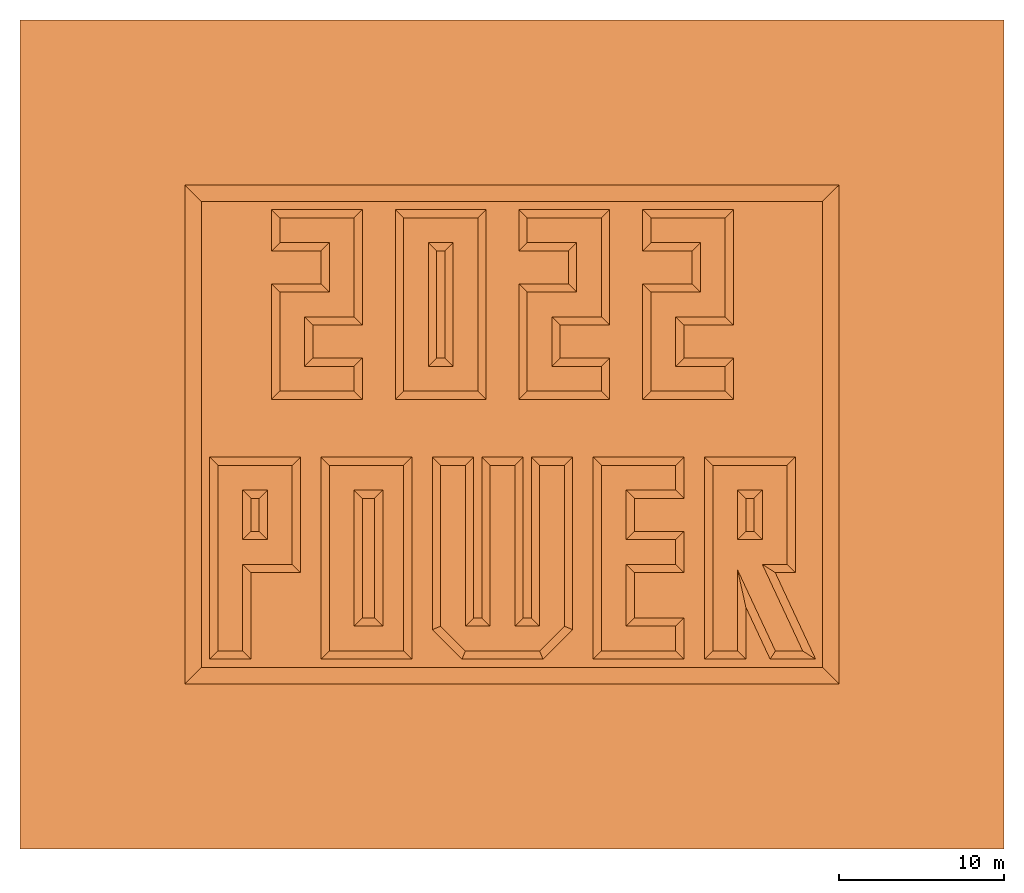
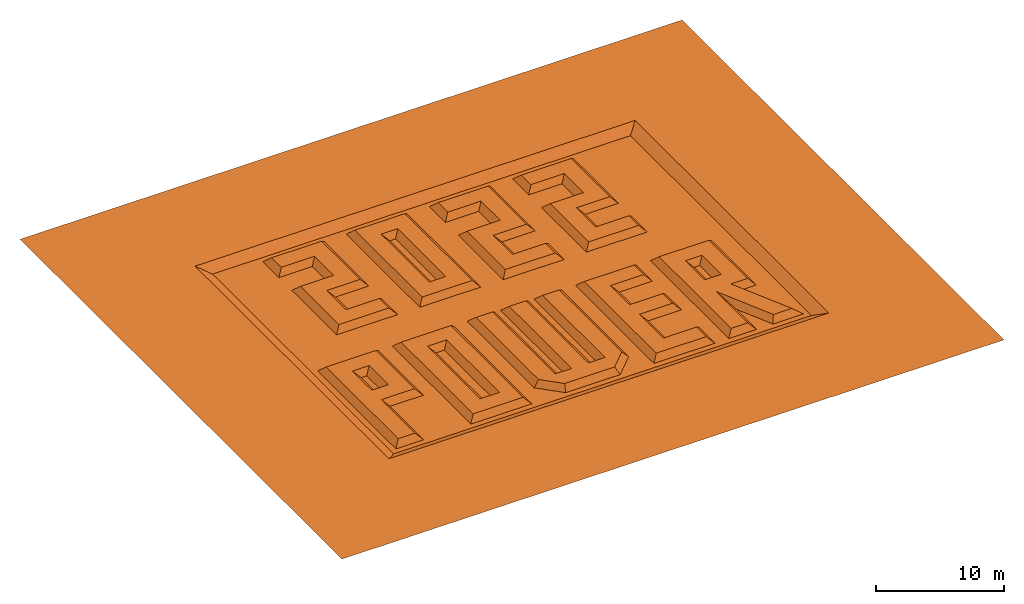
# One storey: 1 proxy.
"""IFC2X3 building model written with IfcOpenShell, lengths in millimetres."""

import ifcopenshell
import ifcopenshell.guid

model = None  # the IFC model being written
_history = None  # IfcOwnerHistory: only IFC2X3 demands one
_inside = {}  # id of a spatial element -> (the spatial element, [elements in it])
_under = {}  # id of a project, library or spatial element -> (it, [spatial elements below it])
_declared = {}  # id of a project -> (the project, [libraries it declares])
_typed = {}  # id of a type object -> (the type object, [elements of that type])
_made_of = {}  # id of a material, layer set ... -> (it, [elements and type objects made of it])


def new_model(schema):
    """Start an empty IFC model of exactly this schema.

    Asked for "IFC4X3", IfcOpenShell would pick the latest addendum, in which some entities
    have other attributes; the version numbers below select the first issue.
    IFC2X3 requires an IfcOwnerHistory on every rooted entity: one is made here for all.
    """
    global model, _history
    if schema == "IFC4X3":
        model = ifcopenshell.file(schema_version=(4, 3, 0, 0))
    else:
        model = ifcopenshell.file(schema=schema)
    _inside.clear()
    _under.clear()
    _declared.clear()
    _typed.clear()
    _made_of.clear()
    _history = None
    if model.schema == "IFC2X3":
        org = make("IfcOrganization", Name="unknown")
        user = make(
            "IfcPersonAndOrganization",
            ThePerson=make("IfcPerson", FamilyName="unknown"),
            TheOrganization=org,
        )
        app = make(
            "IfcApplication",
            ApplicationDeveloper=org,
            Version="unknown",
            ApplicationFullName="unknown",
            ApplicationIdentifier="unknown",
        )
        _history = make(
            "IfcOwnerHistory",
            OwningUser=user,
            OwningApplication=app,
            ChangeAction="ADDED",
            CreationDate=0,
        )
    return model


def make(cls, **values):
    """One entity of the class cls with the attributes given. An attribute that is None is left unset."""
    return model.create_entity(
        cls, **{name: value for name, value in values.items() if value is not None}
    )


def entity(cls, *values):
    """Any entity or typed value of the class cls, its attributes in the order of the schema. None: left unset."""
    e = model.create_entity(cls)
    for i, value in enumerate(values):
        if value is not None:
            e[i] = value
    return e


def rooted(cls, **values):
    """An entity with a GlobalId (a new one), such as an element, a storey or a relation."""
    return make(cls, GlobalId=ifcopenshell.guid.new(), OwnerHistory=_history, **values)


def si_unit(unit_type, name, prefix=None):
    """IfcSIUnit, for example si_unit("LENGTHUNIT", "METRE", prefix="MILLI")."""
    return make("IfcSIUnit", UnitType=unit_type, Prefix=prefix, Name=name)


def converted_unit(unit_type, name, factor, base, dimensions=None, offset=None):
    """IfcConversionBasedUnit, such as the inch: factor (a typed value) times the base unit."""
    return make(
        "IfcConversionBasedUnit"
        if offset is None
        else "IfcConversionBasedUnitWithOffset",
        ConversionOffset=offset,
        Dimensions=None
        if dimensions is None
        else entity("IfcDimensionalExponents", *dimensions),
        UnitType=unit_type,
        Name=name,
        ConversionFactor=make(
            "IfcMeasureWithUnit", ValueComponent=factor, UnitComponent=base
        ),
    )


def assignment(units):
    """IfcUnitAssignment: the units of a project."""
    return None if units is None else make("IfcUnitAssignment", Units=units)


def point(xyz):
    """IfcCartesianPoint."""
    return None if xyz is None else make("IfcCartesianPoint", Coordinates=xyz)


def direction(xyz):
    """IfcDirection."""
    return None if xyz is None else make("IfcDirection", DirectionRatios=xyz)


def frame(location, z_axis=None, x_axis=None):
    """IfcAxis2Placement3D, a coordinate frame: its origin and axes. An axis left out is left unset."""
    return make(
        "IfcAxis2Placement3D",
        Location=point(location),
        Axis=direction(z_axis),
        RefDirection=direction(x_axis),
    )


def origin():
    """The frame at (0, 0, 0) with its axes left unset."""
    return frame((0.0, 0.0, 0.0))


def origin_with_axes():
    """The frame at (0, 0, 0) with the z axis (0, 0, 1) and the x axis (1, 0, 0) written out."""
    return frame((0.0, 0.0, 0.0), z_axis=(0.0, 0.0, 1.0), x_axis=(1.0, 0.0, 0.0))


def place(relative_to, where):
    """IfcLocalPlacement: puts the frame where relative to a parent placement (None: the world)."""
    return make(
        "IfcLocalPlacement", PlacementRelTo=relative_to, RelativePlacement=where
    )


def context(
    kind, dimensions, precision=None, world=None, true_north=None, identifier=None
):
    """IfcGeometricRepresentationContext, for example the 3D "Model" context."""
    return make(
        "IfcGeometricRepresentationContext",
        ContextIdentifier=identifier,
        ContextType=kind,
        CoordinateSpaceDimension=dimensions,
        Precision=precision,
        WorldCoordinateSystem=world,
        TrueNorth=true_north,
    )


def project(units=None, contexts=None):
    """IfcProject with its units and contexts."""
    return rooted(
        "IfcProject",
        Name="project",
        RepresentationContexts=contexts,
        UnitsInContext=assignment(units),
    )


def spatial(cls, under=None, at=None, **own):
    """A site, building, storey or space (cls), placed at a placement, below another one or the project."""
    s = rooted(cls, ObjectPlacement=at, **own)
    if under is not None:
        _under.setdefault(under.id(), (under, []))[1].append(s)
    return s


def faces_of(points, faces, orient=None, outer=None):
    """IfcFace entities. A face is a list of loops; a loop is a list of indices into points, from 0.

    orient and outer hold one flag for each loop. By default every Orientation is true, the
    first loop of a face is its IfcFaceOuterBound and the others are IfcFaceBound.
    """
    made = []
    for i, loops in enumerate(faces):
        bounds = []
        for j, loop in enumerate(loops):
            is_outer = j == 0 if outer is None else outer[i][j]
            bounds.append(
                make(
                    "IfcFaceOuterBound" if is_outer else "IfcFaceBound",
                    Bound=make("IfcPolyLoop", Polygon=[points[k] for k in loop]),
                    Orientation=True if orient is None else orient[i][j],
                )
            )
        made.append(make("IfcFace", Bounds=bounds))
    return made


def faceted_brep(points, faces, orient=None, outer=None, voids=None):
    """IfcFacetedBrep: a solid bounded by flat faces; with voids (closed shells), ...WithVoids."""
    shared = [point(p) for p in points]
    hull = make("IfcClosedShell", CfsFaces=faces_of(shared, faces, orient, outer))
    if voids is None:
        return make("IfcFacetedBrep", Outer=hull)
    return make(
        "IfcFacetedBrepWithVoids",
        Outer=hull,
        Voids=[
            make(cls, CfsFaces=faces_of(shared, fs, o, b)) for cls, fs, o, b in voids
        ],
    )


def shape(context_of_items, identifier, shape_type, items):
    """IfcShapeRepresentation: the items that make up one representation, for example the "Body"."""
    return make(
        "IfcShapeRepresentation",
        ContextOfItems=context_of_items,
        RepresentationIdentifier=identifier,
        RepresentationType=shape_type,
        Items=items,
    )


def made_of(thing, what):
    """Note that an element or type object is made of a material, layer set ...; save() writes the relation."""
    if what is not None:
        _made_of.setdefault(what.id(), (what, []))[1].append(thing)
    return thing


def element(
    cls,
    number,
    at=None,
    inside=None,
    cuts=None,
    type_object=None,
    material=None,
    context=None,
    identifier="Body",
    shape_type=None,
    held_by="IfcProductDefinitionShape",
    body=None,
    shapes=None,
    **own,
):
    """One element of the class cls, such as IfcWall. Its Tag is "e" and its number.

    at: its placement. inside: the storey or other place that contains it. cuts: it is an
    opening in that element (IfcRelVoidsElement). A single representation is given by context,
    identifier, shape_type and body (its items); several are given by shapes. held_by: the class
    of the entity that holds the representations. save() writes the other relations.
    """
    e = rooted(cls, Tag="e%d" % number, ObjectPlacement=at, **own)
    if body is not None:
        shapes = [shape(context, identifier, shape_type, body)]
    if shapes is not None:
        e.Representation = make(held_by, Representations=shapes)
    if inside is not None:
        _inside.setdefault(inside.id(), (inside, []))[1].append(e)
    if cuts is not None:
        rooted(
            "IfcRelVoidsElement", RelatingBuildingElement=cuts, RelatedOpeningElement=e
        )
    if type_object is not None:
        _typed.setdefault(type_object.id(), (type_object, []))[1].append(e)
    return made_of(e, material)


def aggregate(whole, parts):
    """IfcRelAggregates: a whole, such as a stair, and the parts it consists of."""
    return rooted("IfcRelAggregates", RelatingObject=whole, RelatedObjects=parts)


def save(model, path):
    """Write the relations noted so far, then the file.

    IfcRelAggregates (storeys below a building ...), IfcRelContainedInSpatialStructure (elements
    in a storey), IfcRelDefinesByType, IfcRelAssociatesMaterial and IfcRelDeclares: one each for
    every whole, place, type object, material and project.
    """
    for whole, parts in _under.values():
        aggregate(whole, parts)
    for where, things in _inside.values():
        rooted(
            "IfcRelContainedInSpatialStructure",
            RelatedElements=things,
            RelatingStructure=where,
        )
    for kind, things in _typed.values():
        rooted("IfcRelDefinesByType", RelatedObjects=things, RelatingType=kind)
    for what, things in _made_of.values():
        rooted("IfcRelAssociatesMaterial", RelatedObjects=things, RelatingMaterial=what)
    for by, libraries in _declared.values():
        rooted("IfcRelDeclares", RelatingContext=by, RelatedDefinitions=libraries)
    model.write(path)


model = new_model("IFC2X3")

# Units and contexts
model_context = context("Model", 3, precision=1e-05, world=origin(), true_north=direction((0.0, 1.0, 0.0)))
ifc_project = project(units=[si_unit("LENGTHUNIT", "METRE", prefix="MILLI"), si_unit("AREAUNIT", "SQUARE_METRE"), si_unit("VOLUMEUNIT", "CUBIC_METRE"), converted_unit("PLANEANGLEUNIT", "DEGREE", entity("IfcPlaneAngleMeasure", 0.01745), si_unit("PLANEANGLEUNIT", "RADIAN"), dimensions=[0, 0, 0, 0, 0, 0, 0]), si_unit("SOLIDANGLEUNIT", "STERADIAN"), si_unit("MASSUNIT", "GRAM"), si_unit("TIMEUNIT", "SECOND"), si_unit("THERMODYNAMICTEMPERATUREUNIT", "DEGREE_CELSIUS"), si_unit("LUMINOUSINTENSITYUNIT", "LUMEN")], contexts=[model_context])

# Site, building, storey
site_placement = place(None, origin_with_axes())
site = spatial("IfcSite", under=ifc_project, at=site_placement, CompositionType="ELEMENT")
building_placement = place(site_placement, origin_with_axes())
building = spatial("IfcBuilding", under=site, at=building_placement, Name="Default Building", CompositionType="ELEMENT")
storey_placement = place(building_placement, origin_with_axes())
storey = spatial("IfcBuildingStorey", under=building, at=storey_placement, Name="Default Building Storey", CompositionType="ELEMENT", Elevation=0.0)

# Proxy
proxy_placement = place(storey_placement, origin_with_axes())
element("IfcBuildingElementProxy", 1, at=proxy_placement, inside=storey, Name="Object", context=model_context, shape_type="Brep", body=[
    faceted_brep([(25750.00000000009, 36250.00000000007, -499.9999999999991), (25250.00000000009, 36250.00000000007, -499.9999999999991), (25250.00000000009, 29750.00000000006, -499.9999999999991), (25750.00000000009, 29750.00000000006, -499.9999999999991), (44500.00000000017, 21250.00000000011, -499.9999999999998), (44000.00000000016, 21250.00000000011, -499.9999999999998), (44000.00000000016, 19250.00000000011, -499.9999999999998), (44500.00000000017, 19250.00000000011, -499.9999999999998), (18749.99999999999, 12000.0, 1.804778548830654e-13), (23249.99999999999, 12000.0, 1.804778548830654e-13), (23250.00000000001, 23250.00000000001, 1.804778548830654e-13), (18749.99999999999, 23250.00000000001, 1.804778548830654e-13), (20250.00000000002, 21750.00000000001, 1.804778548830654e-13), (21992.00000000001, 21750.00000000001, 1.804778548830654e-13), (21992.00000000001, 13500.0, 1.804778548830654e-13), (20250.0, 13500.0, 1.804778548830654e-13), (14500.0, 21250.0, -499.9999999999998), (14000.0, 21250.0, -499.9999999999998), (14000.0, 19250.0, -499.9999999999998), (14500.0, 19250.0, -499.9999999999998), (12000.0, 12000.0, 1.804778548830654e-13), (13500.0, 12000.0, 1.804778548830654e-13), (13500.0, 17250.0, 1.804778548830654e-13), (16499.99999999999, 17250.0, 1.804778548830654e-13), (16499.99999999999, 23250.00000000001, 1.804778548830654e-13), (12000.0, 23250.00000000001, 1.804778548830654e-13), (15000.0, 18750.0, 1.804778548830654e-13), (13500.0, 18750.0, 1.804778548830654e-13), (13500.0, 21750.00000000001, 1.804778548830654e-13), (15000.0, 21750.00000000001, 1.804778548830654e-13), (21492.0, 14000.0, -499.9999999999998), (21492.0, 21250.0, -499.9999999999998), (20750.00000000002, 21250.0, -499.9999999999998), (20750.00000000002, 14000.0, -499.9999999999998), (15250.00000000007, 38750.00000000008, -499.9999999999991), (15750.00000000007, 38250.00000000008, 9.023892744153272e-13), (20250.00000000007, 38250.00000000008, 9.023892744153272e-13), (20750.00000000007, 38750.00000000008, -499.9999999999991), (17750.00000000006, 29750.00000000006, -499.9999999999991), (17250.00000000005, 29250.00000000006, 9.023892744153272e-13), (20250.00000000007, 29250.00000000006, 9.023892744153272e-13), (20750.00000000007, 29750.00000000006, -499.9999999999991), (18750.00000000006, 33750.00000000007, 9.023892744153272e-13), (18250.00000000006, 34250.00000000007, -499.9999999999991), (15250.00000000007, 34250.00000000007, -499.9999999999991), (15750.00000000007, 33750.00000000007, 9.023892744153272e-13), (30750.00000000007, 33750.00000000007, 9.023892744153272e-13), (30250.00000000006, 34250.00000000007, -499.9999999999991), (30250.00000000006, 27250.00000000006, -499.9999999999991), (30750.00000000007, 27750.00000000007, 9.023892744153272e-13), (33250.00000000007, 36250.00000000007, -499.9999999999991), (33750.00000000007, 36750.00000000007, 9.023892744153272e-13), (30750.00000000007, 36750.00000000007, 9.023892744153272e-13), (30250.00000000006, 36250.00000000007, -499.9999999999991), (37750.00000000007, 34250.00000000007, -499.9999999999991), (38250.00000000007, 33750.00000000007, 9.023892744153272e-13), (41250.00000000006, 33750.00000000007, 9.023892744153272e-13), (40750.00000000006, 34250.00000000007, -499.9999999999991), (43250.00000000007, 38750.00000000008, -499.9999999999991), (42750.00000000007, 38250.00000000008, 9.023892744153272e-13), (42750.00000000007, 32250.00000000006, 9.023892744153272e-13), (43250.00000000007, 31750.00000000005, -499.9999999999991), (30250.00000000006, 38750.00000000008, -499.9999999999991), (30750.00000000007, 38250.00000000008, 9.023892744153272e-13), (35250.00000000006, 38250.00000000008, 9.023892744153272e-13), (35750.00000000006, 38750.00000000008, -499.9999999999991), (39750.00000000008, 29250.00000000006, 9.023892744153272e-13), (40250.00000000006, 29750.00000000006, -499.9999999999991), (40250.00000000006, 31750.00000000005, -499.9999999999991), (39750.00000000008, 32250.00000000006, 9.023892744153272e-13), (26250.00000000009, 36750.00000000007, 9.023892744153272e-13), (24750.00000000009, 36750.00000000007, 9.023892744153272e-13), (17250.00000000005, 32250.00000000006, 9.023892744153272e-13), (17750.00000000006, 31750.00000000005, -499.9999999999991), (20750.00000000007, 31750.00000000005, -499.9999999999991), (20250.00000000007, 32250.00000000006, 9.023892744153272e-13), (20250.00000000007, 27750.00000000007, 9.023892744153272e-13), (20750.00000000007, 27250.00000000006, -499.9999999999991), (37750.00000000007, 27250.00000000006, -499.9999999999991), (38250.00000000007, 27750.00000000007, 9.023892744153272e-13), (28250.00000000008, 38750.00000000008, -499.9999999999991), (27750.00000000008, 38250.00000000008, 9.023892744153272e-13), (27750.00000000008, 27750.00000000007, 9.023892744153272e-13), (28250.00000000008, 27250.00000000006, -499.9999999999991), (22750.00000000008, 38750.00000000008, -499.9999999999991), (23250.00000000008, 38250.00000000008, 9.023892744153272e-13), (43250.00000000007, 27250.00000000006, -499.9999999999991), (42750.00000000007, 27750.00000000007, 9.023892744153272e-13), (43250.00000000007, 29750.00000000006, -499.9999999999991), (42750.00000000007, 29250.00000000006, 9.023892744153272e-13), (40750.00000000006, 36250.00000000007, -499.9999999999991), (41250.00000000006, 36750.00000000007, 9.023892744153272e-13), (38250.00000000007, 36750.00000000007, 9.023892744153272e-13), (37750.00000000007, 36250.00000000007, -499.9999999999991), (15250.00000000007, 27250.00000000006, -499.9999999999991), (15750.00000000007, 27750.00000000007, 9.023892744153272e-13), (22750.00000000008, 27250.00000000006, -499.9999999999991), (23250.00000000008, 27750.00000000007, 9.023892744153272e-13), (33750.00000000007, 33750.00000000007, 9.023892744153272e-13), (33250.00000000007, 34250.00000000007, -499.9999999999991), (26250.00000000009, 29250.00000000006, 9.023892744153272e-13), (24750.00000000009, 29250.00000000006, 9.023892744153272e-13), (18250.00000000006, 36250.00000000007, -499.9999999999991), (18750.00000000006, 36750.00000000007, 9.023892744153272e-13), (15750.00000000007, 36750.00000000007, 9.023892744153272e-13), (15250.00000000007, 36250.00000000007, -499.9999999999991), (37750.00000000007, 38750.00000000008, -499.9999999999991), (38250.00000000007, 38250.00000000008, 9.023892744153272e-13), (35250.00000000006, 27750.00000000007, 9.023892744153272e-13), (35750.00000000006, 27250.00000000006, -499.9999999999991), (35750.00000000006, 29750.00000000006, -499.9999999999991), (35250.00000000006, 29250.00000000006, 9.023892744153272e-13), (35750.00000000006, 31750.00000000005, -499.9999999999991), (35250.00000000006, 32250.00000000006, 9.023892744153272e-13), (32250.00000000007, 32250.00000000006, 9.023892744153272e-13), (32750.00000000007, 31750.00000000005, -499.9999999999991), (32250.00000000007, 29250.00000000006, 9.023892744153272e-13), (32750.00000000007, 29750.00000000006, -499.9999999999991), (47448.11520531395, 12000.0000000001, 1.804778548830661e-13), (45793.04832687019, 12000.0000000001, 1.804778548830659e-13), (45474.51319646642, 11500.00000000011, -499.9999999999998), (45793.04832687019, 11500.00000000011, -499.9999999999998), (46948.11520531391, 11500.00000000011, -499.9999999999997), (48232.95799387265, 11500.00000000011, -499.9999999999998), (47901.26909883226, 12211.30913087044, -499.9999999999997), (45784.84278855896, 16750.00000000011, -499.9999999999998), (45000.00000000017, 17250.00000000011, 1.804778548830665e-13), (42000.00000000018, 12000.0000000001, 1.804778548830654e-13), (43500.00000000018, 12000.0000000001, 1.804778548830654e-13), (43500.00000000016, 16917.45800603568, 1.80477854883066e-13), (46500.00000000015, 17250.00000000011, 1.804778548830654e-13), (46500.00000000015, 23250.00000000012, 1.804778548830654e-13), (42000.00000000018, 23250.00000000012, 1.804778548830654e-13), (45000.00000000017, 18750.00000000011, 1.804778548830654e-13), (43500.00000000016, 18750.00000000011, 1.804778548830654e-13), (43500.00000000016, 21750.00000000011, 1.804778548830654e-13), (45000.00000000017, 21750.00000000011, 1.804778548830654e-13), (44000.00000000016, 14662.10375420471, -499.9999999999998), (45339.89443335183, 11788.69086912975, -499.9999999999998), (44000.00000000016, 11500.00000000011, -499.9999999999998), (14000.0, 11500.0, -499.9999999999998), (14000.0, 16750.0, -499.9999999999998), (16999.99999999999, 16750.0, -499.9999999999998), (47000.00000000015, 16750.00000000011, -499.9999999999998), (23750.00000000001, 23750.00000000001, -499.9999999999998), (18249.99999999999, 23750.00000000001, -499.9999999999998), (11499.99999999999, 23750.00000000001, -499.9999999999998), (11499.99999999999, 11500.0, -499.9999999999998), (41500.00000000017, 11500.00000000011, -499.9999999999998), (47000.00000000015, 23750.00000000011, -499.9999999999998), (41500.00000000017, 23750.00000000011, -499.9999999999998), (16999.99999999999, 23750.00000000001, -499.9999999999998), (33000.00000000012, 13499.99999999993, 1.98525640371372e-12), (33500.00000000012, 13292.99999999996, -499.9999999999998), (33500.00000000012, 23750.00000000011, -499.9999999999998), (33000.00000000012, 23250.00000000016, 1.98525640371372e-12), (31707.00000000012, 11499.99999999994, -499.9999999999998), (31500.00000000011, 11999.99999999994, 1.98525640371372e-12), (27000.00000000014, 11999.99999999995, 1.98525640371372e-12), (26792.89321881361, 11499.99999999989, -499.9999999999998), (18249.99999999999, 11500.0, -499.9999999999998), (23749.99999999999, 11500.0, -499.9999999999998), (36750.00000000015, 21750.00000000011, 1.804778548830654e-13), (37250.00000000016, 21250.00000000011, -499.9999999999998), (40250.00000000015, 21250.00000000011, -499.9999999999998), (39750.00000000015, 21750.00000000011, 1.804778548830654e-13), (36750.00000000015, 18750.00000000011, 1.804778548830654e-13), (39750.00000000017, 23250.00000000012, 1.804778548830654e-13), (35250.00000000015, 23250.00000000012, 1.804778548830654e-13), (35250.00000000015, 12000.0000000001, 1.804778548830654e-13), (39750.00000000015, 12000.0000000001, 1.804778548830654e-13), (39750.00000000017, 13500.0000000001, 1.804778548830654e-13), (36750.00000000015, 13500.0000000001, 1.804778548830654e-13), (36750.00000000015, 17250.00000000011, 1.804778548830654e-13), (39750.00000000017, 17250.00000000011, 1.804778548830654e-13), (39750.00000000017, 18750.00000000011, 1.804778548830654e-13), (37250.00000000016, 14000.00000000011, -499.9999999999998), (40250.00000000017, 14000.00000000011, -499.9999999999998), (25500.00000000004, 13499.99999999994, 1.98525640371372e-12), (25000.00000000013, 13292.89321881348, -499.9999999999998), (37250.00000000016, 19250.00000000011, -499.9999999999998), (40250.00000000017, 19250.00000000011, -499.9999999999998), (40250.00000000015, 11500.00000000011, -499.9999999999998), (31500.00000000013, 23250.00000000002, 1.98525640371372e-12), (31500.00000000011, 13499.99999999997, 1.98525640371372e-12), (30000.00000000018, 13500.00000000008, 1.98525640371372e-12), (30000.00000000013, 23250.00000000006, 1.98525640371372e-12), (28500.00000000005, 23250.00000000006, 1.98525640371372e-12), (28500.00000000008, 13500.00000000009, 1.98525640371372e-12), (27000.00000000005, 13500.0, 1.98525640371372e-12), (27000.00000000014, 23250.00000000003, 1.98525640371372e-12), (25500.00000000011, 23250.00000000006, 1.98525640371372e-12), (28000.00000000001, 14000.00000000009, -499.9999999999998), (27500.00000000001, 14000.00000000006, -499.9999999999998), (30500.00000000016, 23749.99999999992, -499.9999999999998), (28000.00000000005, 23750.00000000001, -499.9999999999998), (40250.00000000017, 23750.00000000011, -499.9999999999998), (31000.00000000018, 23750.00000000008, -499.9999999999998), (34750.00000000012, 23750.00000000011, -499.9999999999998), (34750.00000000012, 11500.00000000011, -499.9999999999998), (37250.00000000016, 16750.00000000011, -499.9999999999998), (27500.00000000012, 23750.00000000002, -499.9999999999998), (25000.00000000002, 23750.00000000001, -499.9999999999998), (40250.00000000017, 16750.00000000011, -499.9999999999998), (31000.00000000013, 14000.00000000002, -499.9999999999998), (30500.00000000023, 14000.00000000007, -499.9999999999998), (48651.77402448355, 11000.0, -499.9999999999996), (49651.77402448358, 10000.0, 3.609557097661309e-13), (49651.77402448358, 40250.00000000007, -9.023892744153272e-14), (48651.77402448355, 39250.00000000008, -499.9999999999993), (10000.0, 10000.0, -9.023892744153272e-14), (10999.99999999999, 11000.0, -500.0), (10999.99999999999, 39250.00000000008, -499.9999999999996), (10000.0, 40250.00000000007, -9.023892744153272e-14), (59651.77402448357, 50250.00000000007, 0.0), (0.0, 50250.00000000007, -3.609557097661309e-13), (0.0, 0.0, 0.0), (59651.77402448357, 0.0, 3.609557097661309e-13)], [[[0, 1, 2, 3]], [[4, 5, 6, 7]], [[8, 9, 10, 11], [12, 13, 14, 15]], [[16, 17, 18, 19]], [[20, 21, 22, 23, 24, 25], [26, 27, 28, 29]], [[30, 31, 32, 33]], [[34, 35, 36, 37]], [[38, 39, 40, 41]], [[42, 43, 44, 45]], [[46, 47, 48, 49]], [[50, 51, 52, 53]], [[54, 55, 56, 57]], [[58, 59, 60, 61]], [[62, 63, 64, 65]], [[66, 67, 68, 69]], [[0, 70, 71, 1]], [[72, 73, 74, 75]], [[76, 77, 41, 40]], [[55, 54, 78, 79]], [[80, 81, 82, 83]], [[61, 60, 69, 68]], [[84, 85, 81, 80]], [[86, 87, 79, 78]], [[87, 86, 88, 89]], [[90, 91, 92, 93]], [[63, 62, 53, 52]], [[45, 44, 94, 95]], [[85, 84, 96, 97]], [[47, 46, 98, 99]], [[97, 82, 81, 85], [71, 70, 100, 101]], [[95, 94, 77, 76]], [[57, 56, 91, 90]], [[3, 100, 70, 0]], [[1, 71, 101, 2]], [[100, 3, 2, 101]], [[89, 88, 67, 66]], [[39, 38, 73, 72]], [[102, 103, 104, 105]], [[106, 107, 59, 58]], [[97, 96, 83, 82]], [[35, 34, 105, 104]], [[37, 36, 75, 74]], [[103, 102, 43, 42]], [[60, 59, 107, 92, 91, 56, 55, 79, 87, 89, 66, 69]], [[107, 106, 93, 92]], [[99, 98, 51, 50]], [[108, 109, 110, 111]], [[112, 113, 114, 115]], [[113, 64, 63, 52, 51, 98, 46, 49, 108, 111, 116, 114]], [[109, 108, 49, 48]], [[116, 117, 115, 114]], [[111, 110, 117, 116]], [[65, 64, 113, 112]], [[75, 36, 35, 104, 103, 42, 45, 95, 76, 40, 39, 72]], [[118, 119, 120, 121, 122, 123]], [[118, 123, 124, 125, 126]], [[127, 128, 129, 119, 118, 126, 130, 131, 132], [133, 134, 135, 136]], [[135, 134, 6, 5]], [[134, 133, 7, 6]], [[120, 119, 129, 137, 138]], [[137, 129, 128, 139]], [[135, 5, 4, 136]], [[30, 33, 15, 14]], [[32, 31, 13, 12]], [[28, 17, 16, 29]], [[21, 140, 141, 22]], [[22, 141, 142, 23]], [[126, 125, 143, 130]], [[144, 145, 11, 10]], [[4, 7, 133, 136]], [[146, 147, 20, 25]], [[31, 30, 14, 13]], [[17, 28, 27, 18]], [[16, 19, 26, 29]], [[148, 139, 128, 127]], [[130, 143, 149, 131]], [[150, 148, 127, 132]], [[146, 25, 24, 151]], [[152, 153, 154, 155]], [[156, 157, 158, 159]], [[26, 19, 18, 27]], [[156, 153, 152, 157]], [[160, 161, 9, 8]], [[147, 140, 21, 20]], [[150, 132, 131, 149]], [[33, 32, 12, 15]], [[161, 144, 10, 9]], [[145, 160, 8, 11]], [[162, 163, 164, 165]], [[166, 162, 165, 167, 168, 169, 170, 171, 172, 173, 174, 175]], [[176, 172, 171, 177]], [[159, 158, 178, 179]], [[180, 166, 175, 181]], [[177, 171, 170, 182]], [[158, 157, 152, 155, 183, 184, 185, 186, 187, 188, 189, 190, 191, 178]], [[188, 192, 193, 189]], [[186, 194, 195, 187]], [[196, 167, 165, 164]], [[155, 154, 197, 183]], [[168, 198, 199, 169]], [[172, 176, 200, 173]], [[190, 201, 202, 191]], [[191, 202, 179, 178]], [[173, 200, 203, 174]], [[166, 180, 163, 162]], [[192, 188, 187, 195]], [[169, 199, 182, 170]], [[23, 142, 151, 24]], [[184, 204, 205, 185]], [[204, 184, 183, 197]], [[185, 205, 194, 186]], [[189, 193, 201, 190]], [[181, 175, 174, 203]], [[198, 168, 167, 196]], [[206, 207, 208, 209]], [[210, 211, 212, 213]], [[211, 206, 209, 212], [148, 150, 149, 143, 125, 124, 123, 122, 121, 120, 138, 137, 139], [109, 48, 47, 99, 50, 53, 62, 65, 112, 115, 117, 110], [197, 154, 153, 156, 159, 179, 202, 201, 193, 192, 195, 194, 205, 204], [77, 94, 44, 43, 102, 105, 34, 37, 74, 73, 38, 41], [88, 86, 78, 54, 57, 90, 93, 106, 58, 61, 68, 67], [80, 83, 96, 84], [144, 161, 160, 145], [181, 203, 200, 176, 177, 182, 199, 198, 196, 164, 163, 180], [147, 146, 151, 142, 141, 140]], [[211, 210, 207, 206]], [[214, 215, 216, 217], [213, 208, 207, 210]], [[209, 208, 213, 212]]]),
])

save(model, "model.ifc")
